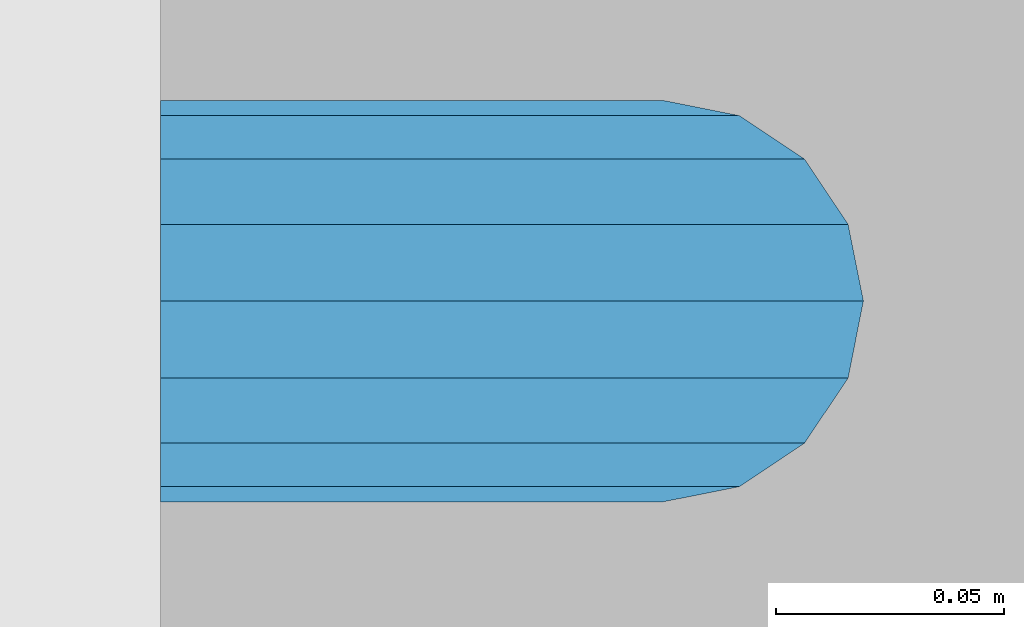
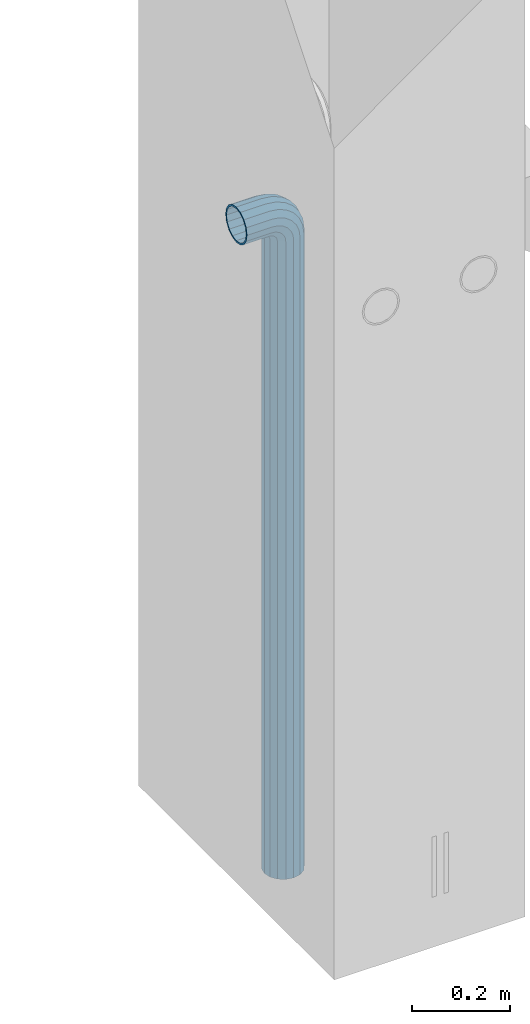
# One storey, part 7 of 41: 1 beam, 2 elements without a shape of their own.
"""IFC2X3 building model written with IfcOpenShell, lengths in millimetres."""

from ifc_helpers import new_model, si_unit, frame, origin_with_axes, place, context, subcontext, project, spatial, faceted_brep, material, type_object, element, aggregate, save


model = new_model("IFC2X3")

# Units and contexts
model_context = context("Model", 3, precision=1e-05, world=origin_with_axes())
body_context = subcontext(model_context, "Body", "Model", "MODEL_VIEW")
ifc_project = project(units=[si_unit("LENGTHUNIT", "METRE", prefix="MILLI"), si_unit("AREAUNIT", "SQUARE_METRE"), si_unit("VOLUMEUNIT", "CUBIC_METRE"), si_unit("MASSUNIT", "GRAM", prefix="KILO"), si_unit("TIMEUNIT", "SECOND"), si_unit("PLANEANGLEUNIT", "RADIAN"), si_unit("SOLIDANGLEUNIT", "STERADIAN"), si_unit("THERMODYNAMICTEMPERATUREUNIT", "DEGREE_CELSIUS"), si_unit("LUMINOUSINTENSITYUNIT", "LUMEN")], contexts=[model_context])

# Site, building, storey
site_placement = place(None, frame((-177556.685383467, -198018.589999756, 1290.0), z_axis=(0.0, 0.0, 1.0), x_axis=(0.788225611989142, -0.615386370180835, 0.0)))
site = spatial("IfcSite", under=ifc_project, at=site_placement, CompositionType="ELEMENT")
building_placement = place(site_placement, origin_with_axes())
building = spatial("IfcBuilding", under=site, at=building_placement, Name="Undefined", CompositionType="ELEMENT")
storey_placement = place(building_placement, origin_with_axes())
storey = spatial("IfcBuildingStorey", under=building, at=storey_placement, Name="Undefined", CompositionType="ELEMENT", Elevation=0.0)

# Assemblies, beam
assembly_1_placement = place(storey_placement, origin_with_axes())
assembly_1 = element("IfcElementAssembly", 1, at=assembly_1_placement, inside=storey, AssemblyPlace="NOTDEFINED", PredefinedType="REINFORCEMENT_UNIT")
assembly_2_placement = place(assembly_1_placement, origin_with_axes())
assembly_2 = element("IfcElementAssembly", 2, at=assembly_2_placement, AssemblyPlace="NOTDEFINED", PredefinedType="RIGID_FRAME")
aggregate(assembly_1, [assembly_2])
ifc_material = material(Name="STEEL/NEG_BETON")
beam_type = type_object("IfcBeamType", PredefinedType="NOTDEFINED")
beam_placement = place(assembly_2_placement, frame((18006.1397254913, 265278.518974686, -1290.0), z_axis=(0.615386370178831, -0.788225611990706, 0.0), x_axis=(0.0, 0.0, 1.0)))
beam = element("IfcBeam", 3, at=beam_placement, type_object=beam_type, material=ifc_material, context=body_context, shape_type="Brep", body=[
    faceted_brep([(0.0, -43.999999753345, 2.88331648334861e-07), (0.0, -40.6506991838105, -16.8380707357428), (1590.0, -40.6506991838105, -16.8380707357428), (1589.99999999999, -43.999999753345, 2.88331648334861e-07), (0.0, -31.1126981254783, -31.1126980838017), (1590.0, -31.1126981254783, -31.1126980838017), (0.0, -16.8380707773322, -40.6506991419883), (1590.0, -16.8380707773322, -40.6506991419883), (0.0, 2.46742274612188e-07, -43.9999997114064), (1590.0, 2.46742274612188e-07, -43.9999997114064), (0.0, 16.8380712707876, -40.6506991418137), (1590.0, 16.8380712707876, -40.6506991418137), (0.0, 31.1126986189047, -31.1126980834524), (1590.0, 31.1126986189047, -31.1126980834524), (0.0, 40.6506996771204, -16.8380707352771), (1590.0, 40.6506996771204, -16.8380707352771), (0.0, 44.0000002465677, 2.88768205791712e-07), (1590.0, 44.0000002465677, 2.88768205791712e-07), (0.0, 40.6506996770622, 16.8380713128427), (1590.0, 40.6506996770622, 16.8380713128427), (0.0, 31.1126986187301, 31.1126986609306), (1590.0, 31.1126986187301, 31.1126986609306), (0.0, 16.8380712705839, 40.6506997191464), (1590.0, 16.8380712705839, 40.6506997191464), (0.0, 2.46509443968534e-07, 44.0000002885354), (1590.0, 2.46509443968534e-07, 44.0000002885354), (0.0, -16.8380707775359, 40.6506997189426), (1590.0, -16.8380707775359, 40.6506997189426), (0.0, -31.1126981256821, 31.1126986605814), (1590.0, -31.1126981256821, 31.1126986605814), (0.0, -40.6506991838978, 16.838071312377), (1590.0, -40.6506991838978, 16.838071312377), (4.47878846898675e-07, -40.0000000634464, 0.0), (4.47878846898675e-07, -36.9551813638827, 15.3073372946019), (1590.0, -36.9551810538396, 15.3073375829845), (1589.99999999999, -39.999999753345, 2.88360752165318e-07), (4.47937054559588e-07, -28.2842713108694, 28.284271247463), (1590.0, -28.2842710008845, 28.2842715359002), (4.4800981413573e-07, -15.3073373580119, 36.9551813004509), (1590.0, -15.3073370480561, 36.9551815889135), (4.48068021796644e-07, -6.34463503956795e-08, 40.0), (1590.0, 2.46538547798991e-07, 40.0000002885645), (4.48140781372786e-07, 15.3073372311774, 36.9551813004509), (1590.0, 15.3073375411332, 36.9551815890882), (4.48213540948927e-07, 28.2842711840058, 28.284271247463), (1590.0, 28.2842714939907, 28.2842715361621), (4.48271748609841e-07, 36.95518123699, 15.3073372946019), (1590.0, 36.9551815469749, 15.3073375833046), (4.48286300525069e-07, 39.9999999365536, 0.0), (1590.0, 40.0000002465677, 2.88768205791712e-07), (4.48271748609841e-07, 36.95518123699, -15.3073372946019), (1590.0, 36.9551815470913, -15.3073370058555), (4.48213540948927e-07, 28.2842711840058, -28.284271247463), (1590.0, 28.2842714941071, -28.2842709587712), (4.48140781372786e-07, 15.3073372311774, -36.9551813004509), (1590.0, 15.3073375413369, -36.9551810117846), (4.48068021796644e-07, -6.34463503956795e-08, -40.0), (1590.0, 2.46742274612188e-07, -39.9999997114064), (4.4800981413573e-07, -15.3073373580119, -36.9551813004509), (1590.0, -15.3073370479106, -36.9551810119592), (4.47937054559588e-07, -28.2842713108694, -28.284271247463), (1590.0, -28.284271000739, -28.2842709590332), (4.47878846898675e-07, -36.9551813638827, -15.3073372946019), (1590.0, -36.9551810537523, -15.3073370062048), (1614.32899023962, -40.7970274245017, 2.88331648334861e-07), (1613.46212746446, -37.5618515044625, 16.8380713124643), (1610.99351113837, -28.3488499511732, 31.1126986606105), (1607.29896571893, -14.5606187349476, 40.6506997189717), (1602.94095225511, 1.70370893206564, 44.0000002885354), (1598.5829387913, 17.9680365990498, 40.6506997191173), (1594.88839337186, 31.7562678153045, 31.1126986609015), (1592.41977704576, 40.9692693687393, 16.8380713128427), (1591.55291427061, 44.2044452888367, 2.88768205791712e-07), (1592.41977704576, 40.9692693687975, -16.8380707352771), (1594.88839337186, 31.7562678154791, -31.1126980834815), (1598.5829387913, 17.9680365993117, -40.6506991418428), (1602.94095225511, 1.70370893226936, -43.9999997114355), (1607.29896571893, -14.5606187347439, -40.6506991419592), (1610.99351113837, -28.3488499509695, -31.1126980837726), (1613.46212746446, -37.5618515043752, -16.8380707356846), (1613.29371405921, -36.9333241193672, 2.88360752165318e-07), (1612.50565699088, -33.9922551010677, -15.3073370062048), (1610.2614603308, -25.6167991434049, -28.2842709590041), (1606.90278267676, -13.0820434923226, -36.9551810119301), (1602.94095225511, 1.70370893226936, -39.9999997114355), (1598.97912183346, 16.4894613568322, -36.9551810117846), (1595.62044417943, 29.0242170079437, -28.284270958713), (1593.37624751934, 37.3996729654609, -15.3073370058846), (1592.58819045101, 40.3407419836731, 2.88739101961255e-07), (1593.37624751934, 37.3996729654027, 15.3073375833337), (1595.62044417943, 29.024217007769, 28.2842715361621), (1598.97912183346, 16.4894613566285, 36.9551815890882), (1602.94095225511, 1.70370893203653, 40.0000002885354), (1606.90278267676, -13.0820434924681, 36.9551815889135), (1610.2614603308, -25.6167991435796, 28.2842715358711), (1612.50565699088, -33.992255101155, 15.3073375829554), (1630.55634918609, -20.2456571130897, -31.1126980837435), (1635.32534971524, -28.5058083309559, -16.8380707356555), (1623.41903551202, -7.88346720003756, -40.6506991419301), (1614.99999999999, 6.69873005751288, -43.9999997113773), (1606.58096448796, 21.2809273150342, -40.6506991418137), (1599.44365081389, 33.6431172280572, -31.1126980834815), (1594.67465028474, 41.903268445807, -16.8380707352771), (1592.99999999999, 44.8038478238741, 2.88768205791712e-07), (1594.67465028474, 41.9032684457197, 16.8380713128427), (1599.44365081389, 33.6431172279117, 31.1126986609306), (1606.58096448796, 21.2809273148305, 40.6506997191173), (1614.99999999999, 6.69873005730915, 44.0000002885936), (1623.41903551202, -7.88346720024128, 40.6506997190008), (1630.55634918609, -20.2456571132934, 31.1126986606687), (1635.32534971524, -28.5058083310141, 16.8380713124934), (1636.99999999999, -31.4063877090521, 2.88418959826231e-07), (1633.47759065022, -25.3053957502707, 15.3073375830427), (1634.99999999999, -27.9422860939521, 2.88389855995774e-07), (1629.14213562372, -17.7961673704849, 28.2842715359293), (1622.65366864729, -6.55781290409504, 36.9551815889718), (1614.99999999999, 6.69873005730915, 40.0000002886227), (1607.34633135269, 19.9552730187133, 36.9551815891173), (1600.85786437626, 31.1936274851323, 28.2842715361621), (1596.52240934976, 38.7028558649763, 15.3073375833628), (1594.99999999999, 41.3397462087451, 2.88797309622169e-07), (1596.52240934976, 38.7028558650345, -15.3073370058555), (1600.85786437626, 31.1936274852778, -28.284270958713), (1607.34633135269, 19.9552730189171, -36.9551810117846), (1614.99999999999, 6.69873005751288, -39.9999997113482), (1622.65366864729, -6.55781290392042, -36.9551810119301), (1629.14213562372, -17.7961673703394, -28.284270958975), (1633.47759065022, -25.3053957501834, -15.3073370061757), (1647.35533905931, -7.35533881263109, -31.1126980836852), (1654.09972428659, -14.099724039901, -16.8380707355391), (1637.26165326253, 2.73834698420251, -40.6506991419301), (1625.35533905931, 14.644661187398, -43.9999997113482), (1613.4490248561, 26.5509753906226, -40.6506991417555), (1603.35533905931, 36.6446611873689, -31.1126980834233), (1596.61095383203, 43.3890464145807, -16.8380707352771), (1594.24264068711, 45.7573595594731, 2.88768205791712e-07), (1596.61095383203, 43.3890464145225, 16.8380713128427), (1603.35533905931, 36.6446611871943, 31.1126986609597), (1613.4490248561, 26.5509753903898, 40.6506997191755), (1625.35533905931, 14.6446611871943, 44.0000002886227), (1637.26165326252, 2.73834698399878, 40.6506997190299), (1647.35533905931, -7.3553388127475, 31.112698660756), (1654.09972428659, -14.0997240400175, 16.8380713125516), (1656.46803743151, -16.4680371848808, 2.88506271317601e-07), (1651.48659835683, -11.4865981102339, 15.3073375831009), (1653.63961030677, -13.6396100601123, 2.88535375148058e-07), (1645.35533905931, -5.3553388127475, 28.2842715359875), (1636.17926106223, 3.82073918430251, 36.9551815890009), (1625.35533905931, 14.6446611871652, 40.0000002885936), (1614.53141705639, 25.4685831901152, 36.9551815891173), (1605.35533905931, 34.6446611872234, 28.2842715362203), (1599.22407976179, 40.7759204847389, 15.3073375833919), (1597.07106781185, 42.9289324347337, 2.88797309622169e-07), (1599.22407976179, 40.7759204847971, -15.3073370058264), (1605.35533905931, 34.6446611873398, -28.284270958713), (1614.53141705639, 25.4685831902898, -36.9551810117264), (1625.35533905931, 14.644661187398, -39.9999997113773), (1636.17926106223, 3.82073918444803, -36.9551810118428), (1645.35533905931, -5.35533881263109, -28.2842709589459), (1651.48659835683, -11.4865981101757, -15.3073370061175), (1660.24565735981, 9.44365106063196, -31.1126980835688), (1668.50580857761, 4.67465053146589, -16.8380707354518), (1647.88346744677, 16.5809647346905, -40.6506991418428), (1633.3012701892, 25.0000002467132, -43.9999997113191), (1618.71907293164, 33.4190357587358, -40.6506991417555), (1606.35688301859, 40.5563494327944, -31.1126980834233), (1598.09673180079, 45.3253499618731, -16.838070735248), (1595.19615242269, 47.0000002465677, 2.88797309622169e-07), (1598.09673180079, 45.3253499617858, 16.8380713128718), (1606.35688301859, 40.5563494326198, 31.1126986609888), (1618.71907293164, 33.419035758503, 40.6506997192046), (1633.3012701892, 25.0000002465094, 44.0000002886809), (1647.88346744677, 16.5809647344868, 40.6506997191173), (1660.24565735981, 9.44365106045734, 31.1126986608433), (1668.50580857761, 4.67465053134947, 16.8380713126389), (1671.40638795571, 3.00000024662586, 2.88593582808971e-07), (1665.30539599685, 6.52240959636401, 15.3073375831882), (1667.94228634057, 5.00000024665496, 2.88622686639428e-07), (1657.79616761703, 10.8578646228416, 28.2842715360748), (1646.55781315062, 17.3463315992267, 36.9551815890882), (1633.3012701892, 25.0000002465094, 40.0000002886809), (1620.04472722778, 32.6536688937922, 36.9551815891464), (1608.80637276137, 39.1421358702646, 28.2842715361912), (1601.29714438156, 43.4775908967713, 15.3073375833628), (1598.66025403783, 45.0000002466259, 2.88797309622169e-07), (1601.29714438156, 43.4775908968586, -15.3073370057973), (1608.80637276137, 39.1421358704101, -28.2842709586548), (1620.04472722778, 32.6536688939959, -36.9551810117264), (1633.3012701892, 25.0000002467132, -39.99999971129), (1646.55781315062, 17.3463315994013, -36.9551810117846), (1657.79616761703, 10.857864622958, -28.2842709588294), (1665.30539599685, 6.52240959645133, -15.307337006001), (1668.34885019768, 29.0064891083166, -31.1126980834524), (1677.56185175105, 26.5378727821808, -16.8380707353354), (1654.56061898146, 32.7010345277959, -40.6506991417555), (1638.29629131443, 37.0590479915554, -43.9999997112609), (1622.0319636474, 41.4170614553732, -40.6506991417264), (1608.24373243118, 45.1116068747942, -31.1126980834233), (1599.03073087781, 47.5802232008427, -16.8380707352771), (1595.79555495772, 48.4470859759604, 2.88797309622169e-07), (1599.03073087781, 47.5802232007554, 16.8380713128427), (1608.24373243118, 45.1116068746196, 31.1126986609597), (1622.0319636474, 41.4170614551695, 40.6506997192628), (1638.29629131443, 37.0590479913517, 44.0000002887391), (1654.56061898146, 32.7010345275921, 40.6506997192337), (1668.34885019768, 29.0064891081711, 31.1126986609306), (1677.56185175105, 26.5378727821226, 16.8380713127845), (1680.79702767114, 25.671010007005, 2.88709998130798e-07), (1673.99225534772, 27.4943432556756, 15.3073375832755), (1676.93332436598, 26.7062861874001, 2.88680894300342e-07), (1665.61679939011, 29.7385399157356, 28.2842715361621), (1653.082043739, 33.0972175697389, 36.9551815891755), (1638.29629131443, 37.0590479913517, 40.00000028871), (1623.51053888986, 41.0208784130227, 36.9551815891755), (1610.97578323875, 44.3795560670551, 28.2842715362203), (1602.60032728114, 46.6237527272024, 15.3073375833919), (1599.65925826287, 47.4118097955652, 2.88826413452625e-07), (1602.60032728114, 46.6237527272606, -15.3073370057682), (1610.97578323875, 44.3795560672297, -28.2842709586548), (1623.51053888986, 41.0208784131974, -36.9551810116682), (1638.29629131443, 37.0590479915554, -39.9999997112609), (1653.082043739, 33.0972175699426, -36.9551810116682), (1665.61679939011, 29.7385399158811, -28.284270958713), (1673.99225534772, 27.4943432557629, -15.3073370058846), (1671.11269837217, 50.0000002466841, -31.1126980833651), (1680.65069943045, 50.0000002466259, -16.838070735248), (1656.83807102403, 50.0000002467132, -40.6506991416682), (1639.99999999997, 50.0000002466841, -43.9999997111736), (1623.16192897591, 50.0000002467132, -40.6506991416682), (1608.88730162777, 50.0000002466259, -31.1126980833942), (1599.34930056949, 50.0000002465968, -16.838070735248), (1595.99999999998, 50.0000002465677, 2.88826413452625e-07), (1599.34930056949, 50.0000002465677, 16.8380713129009), (1608.88730162777, 50.0000002465094, 31.1126986610179), (1623.16192897591, 50.0000002464803, 40.6506997192919), (1639.99999999997, 50.0000002464803, 44.0000002887973), (1656.83807102403, 50.0000002464803, 40.6506997192919), (1671.11269837217, 50.0000002465094, 31.1126986610179), (1680.65069943045, 50.0000002465677, 16.8380713128718), (1684.0, 50.0000002465677, 2.88826413452625e-07), (1676.95518130041, 50.0000002465385, 15.307337583421), (1680.0, 50.0000002465677, 2.88826413452625e-07), (1668.28427124742, 50.0000002465094, 28.2842715362785), (1655.30733729457, 50.0000002465094, 36.9551815892919), (1639.99999999997, 50.0000002464803, 40.0000002887973), (1624.69266270537, 50.0000002465094, 36.9551815892919), (1611.71572875252, 50.0000002465094, 28.2842715362785), (1603.04481869953, 50.0000002465385, 15.307337583421), (1599.99999999998, 50.0000002465677, 2.88826413452625e-07), (1603.04481869953, 50.0000002466259, -15.3073370057682), (1611.71572875252, 50.000000246655, -28.2842709586257), (1624.69266270537, 50.0000002466841, -36.95518101161), (1639.99999999997, 50.0000002466841, -39.9999997111736), (1655.30733729457, 50.0000002466841, -36.95518101161), (1668.28427124742, 50.000000246655, -28.2842709586257), (1676.95518130041, 50.0000002466259, -15.3073370057682), (1680.6506994305, 110.000000246597, -16.838070734957), (1684.0, 110.000000246539, 2.89117451757193e-07), (1671.11269837221, 110.000000246626, -31.1126980830741), (1656.83807102406, 110.000000246655, -40.650699141348), (1640.0, 110.000000246655, -43.9999997108534), (1623.16192897594, 110.000000246655, -40.650699141348), (1608.88730162779, 110.000000246626, -31.1126980830741), (1599.3493005695, 110.000000246597, -16.838070734957), (1596.0, 110.000000246539, 2.89117451757193e-07), (1599.3493005695, 110.000000246509, 16.8380713131919), (1608.88730162779, 110.00000024648, 31.1126986613381), (1623.16192897594, 110.000000246451, 40.6506997195829), (1640.0, 110.000000246422, 44.0000002891175), (1656.83807102406, 110.000000246451, 40.6506997195829), (1671.11269837221, 110.00000024648, 31.1126986613381), (1680.6506994305, 110.000000246509, 16.8380713131919), (1676.95518130045, 110.000000246509, 15.3073375837121), (1680.0, 110.000000246539, 2.89117451757193e-07), (1668.28427124746, 110.000000246451, 28.2842715365696), (1655.3073372946, 110.000000246422, 36.9551815895538), (1640.0, 110.000000246451, 40.0000002891175), (1624.6926627054, 110.000000246422, 36.9551815895538), (1611.71572875254, 110.000000246451, 28.2842715365696), (1603.04481869955, 110.000000246509, 15.3073375837121), (1600.0, 110.000000246539, 2.89117451757193e-07), (1603.04481869955, 110.000000246597, -15.3073370054772), (1611.71572875254, 110.000000246626, -28.2842709583347), (1624.6926627054, 110.000000246626, -36.955181011348), (1640.0, 110.000000246655, -39.9999997108534), (1655.3073372946, 110.000000246626, -36.955181011348), (1668.28427124746, 110.000000246626, -28.2842709583347), (1676.95518130045, 110.000000246597, -15.3073370054772)], [[[0, 1, 2, 3]], [[1, 4, 5, 2]], [[4, 6, 7, 5]], [[6, 8, 9, 7]], [[8, 10, 11, 9]], [[10, 12, 13, 11]], [[12, 14, 15, 13]], [[14, 16, 17, 15]], [[16, 18, 19, 17]], [[18, 20, 21, 19]], [[20, 22, 23, 21]], [[22, 24, 25, 23]], [[24, 26, 27, 25]], [[26, 28, 29, 27]], [[28, 30, 31, 29]], [[30, 0, 3, 31]], [[32, 33, 34, 35]], [[33, 36, 37, 34]], [[36, 38, 39, 37]], [[38, 40, 41, 39]], [[40, 42, 43, 41]], [[42, 44, 45, 43]], [[44, 46, 47, 45]], [[46, 48, 49, 47]], [[48, 50, 51, 49]], [[50, 52, 53, 51]], [[52, 54, 55, 53]], [[54, 56, 57, 55]], [[56, 58, 59, 57]], [[58, 60, 61, 59]], [[60, 62, 63, 61]], [[62, 32, 35, 63]], [[30, 28, 26, 24, 22, 20, 18, 16, 14, 12, 10, 8, 6, 4, 1, 0], [62, 60, 58, 56, 54, 52, 50, 48, 46, 44, 42, 40, 38, 36, 33, 32]], [[31, 3, 64, 65]], [[29, 31, 65, 66]], [[27, 29, 66, 67]], [[25, 27, 67, 68]], [[23, 25, 68, 69]], [[21, 23, 69, 70]], [[19, 21, 70, 71]], [[17, 19, 71, 72]], [[15, 17, 72, 73]], [[13, 15, 73, 74]], [[11, 13, 74, 75]], [[9, 11, 75, 76]], [[7, 9, 76, 77]], [[5, 7, 77, 78]], [[2, 5, 78, 79]], [[3, 2, 79, 64]], [[63, 35, 80, 81]], [[61, 63, 81, 82]], [[59, 61, 82, 83]], [[57, 59, 83, 84]], [[55, 57, 84, 85]], [[53, 55, 85, 86]], [[51, 53, 86, 87]], [[49, 51, 87, 88]], [[47, 49, 88, 89]], [[45, 47, 89, 90]], [[43, 45, 90, 91]], [[41, 43, 91, 92]], [[39, 41, 92, 93]], [[37, 39, 93, 94]], [[34, 37, 94, 95]], [[35, 34, 95, 80]], [[78, 96, 97, 79]], [[77, 98, 96, 78]], [[76, 99, 98, 77]], [[75, 100, 99, 76]], [[74, 101, 100, 75]], [[73, 102, 101, 74]], [[72, 103, 102, 73]], [[71, 104, 103, 72]], [[70, 105, 104, 71]], [[69, 106, 105, 70]], [[68, 107, 106, 69]], [[67, 108, 107, 68]], [[66, 109, 108, 67]], [[65, 110, 109, 66]], [[64, 111, 110, 65]], [[79, 97, 111, 64]], [[95, 112, 113, 80]], [[94, 114, 112, 95]], [[93, 115, 114, 94]], [[92, 116, 115, 93]], [[91, 117, 116, 92]], [[90, 118, 117, 91]], [[89, 119, 118, 90]], [[88, 120, 119, 89]], [[87, 121, 120, 88]], [[86, 122, 121, 87]], [[85, 123, 122, 86]], [[84, 124, 123, 85]], [[83, 125, 124, 84]], [[82, 126, 125, 83]], [[81, 127, 126, 82]], [[80, 113, 127, 81]], [[96, 128, 129, 97]], [[98, 130, 128, 96]], [[99, 131, 130, 98]], [[100, 132, 131, 99]], [[101, 133, 132, 100]], [[102, 134, 133, 101]], [[103, 135, 134, 102]], [[104, 136, 135, 103]], [[105, 137, 136, 104]], [[106, 138, 137, 105]], [[107, 139, 138, 106]], [[108, 140, 139, 107]], [[109, 141, 140, 108]], [[110, 142, 141, 109]], [[111, 143, 142, 110]], [[97, 129, 143, 111]], [[112, 144, 145, 113]], [[114, 146, 144, 112]], [[115, 147, 146, 114]], [[116, 148, 147, 115]], [[117, 149, 148, 116]], [[118, 150, 149, 117]], [[119, 151, 150, 118]], [[120, 152, 151, 119]], [[121, 153, 152, 120]], [[122, 154, 153, 121]], [[123, 155, 154, 122]], [[124, 156, 155, 123]], [[125, 157, 156, 124]], [[126, 158, 157, 125]], [[127, 159, 158, 126]], [[113, 145, 159, 127]], [[128, 160, 161, 129]], [[130, 162, 160, 128]], [[131, 163, 162, 130]], [[132, 164, 163, 131]], [[133, 165, 164, 132]], [[134, 166, 165, 133]], [[135, 167, 166, 134]], [[136, 168, 167, 135]], [[137, 169, 168, 136]], [[138, 170, 169, 137]], [[139, 171, 170, 138]], [[140, 172, 171, 139]], [[141, 173, 172, 140]], [[142, 174, 173, 141]], [[143, 175, 174, 142]], [[129, 161, 175, 143]], [[144, 176, 177, 145]], [[146, 178, 176, 144]], [[147, 179, 178, 146]], [[148, 180, 179, 147]], [[149, 181, 180, 148]], [[150, 182, 181, 149]], [[151, 183, 182, 150]], [[152, 184, 183, 151]], [[153, 185, 184, 152]], [[154, 186, 185, 153]], [[155, 187, 186, 154]], [[156, 188, 187, 155]], [[157, 189, 188, 156]], [[158, 190, 189, 157]], [[159, 191, 190, 158]], [[145, 177, 191, 159]], [[160, 192, 193, 161]], [[162, 194, 192, 160]], [[163, 195, 194, 162]], [[164, 196, 195, 163]], [[165, 197, 196, 164]], [[166, 198, 197, 165]], [[167, 199, 198, 166]], [[168, 200, 199, 167]], [[169, 201, 200, 168]], [[170, 202, 201, 169]], [[171, 203, 202, 170]], [[172, 204, 203, 171]], [[173, 205, 204, 172]], [[174, 206, 205, 173]], [[175, 207, 206, 174]], [[161, 193, 207, 175]], [[176, 208, 209, 177]], [[178, 210, 208, 176]], [[179, 211, 210, 178]], [[180, 212, 211, 179]], [[181, 213, 212, 180]], [[182, 214, 213, 181]], [[183, 215, 214, 182]], [[184, 216, 215, 183]], [[185, 217, 216, 184]], [[186, 218, 217, 185]], [[187, 219, 218, 186]], [[188, 220, 219, 187]], [[189, 221, 220, 188]], [[190, 222, 221, 189]], [[191, 223, 222, 190]], [[177, 209, 223, 191]], [[192, 224, 225, 193]], [[194, 226, 224, 192]], [[195, 227, 226, 194]], [[196, 228, 227, 195]], [[197, 229, 228, 196]], [[198, 230, 229, 197]], [[199, 231, 230, 198]], [[200, 232, 231, 199]], [[201, 233, 232, 200]], [[202, 234, 233, 201]], [[203, 235, 234, 202]], [[204, 236, 235, 203]], [[205, 237, 236, 204]], [[206, 238, 237, 205]], [[207, 239, 238, 206]], [[193, 225, 239, 207]], [[208, 240, 241, 209]], [[210, 242, 240, 208]], [[211, 243, 242, 210]], [[212, 244, 243, 211]], [[213, 245, 244, 212]], [[214, 246, 245, 213]], [[215, 247, 246, 214]], [[216, 248, 247, 215]], [[217, 249, 248, 216]], [[218, 250, 249, 217]], [[219, 251, 250, 218]], [[220, 252, 251, 219]], [[221, 253, 252, 220]], [[222, 254, 253, 221]], [[223, 255, 254, 222]], [[209, 241, 255, 223]], [[239, 225, 256, 257]], [[225, 224, 258, 256]], [[224, 226, 259, 258]], [[226, 227, 260, 259]], [[227, 228, 261, 260]], [[228, 229, 262, 261]], [[229, 230, 263, 262]], [[230, 231, 264, 263]], [[231, 232, 265, 264]], [[232, 233, 266, 265]], [[233, 234, 267, 266]], [[234, 235, 268, 267]], [[235, 236, 269, 268]], [[236, 237, 270, 269]], [[237, 238, 271, 270]], [[238, 239, 257, 271]], [[241, 240, 272, 273]], [[240, 242, 274, 272]], [[242, 243, 275, 274]], [[243, 244, 276, 275]], [[244, 245, 277, 276]], [[245, 246, 278, 277]], [[246, 247, 279, 278]], [[247, 248, 280, 279]], [[248, 249, 281, 280]], [[249, 250, 282, 281]], [[250, 251, 283, 282]], [[251, 252, 284, 283]], [[252, 253, 285, 284]], [[253, 254, 286, 285]], [[254, 255, 287, 286]], [[255, 241, 273, 287]], [[258, 259, 260, 261, 262, 263, 264, 265, 266, 267, 268, 269, 270, 271, 257, 256], [274, 275, 276, 277, 278, 279, 280, 281, 282, 283, 284, 285, 286, 287, 273, 272]]]),
])
aggregate(assembly_2, [beam])

save(model, "model.ifc")
